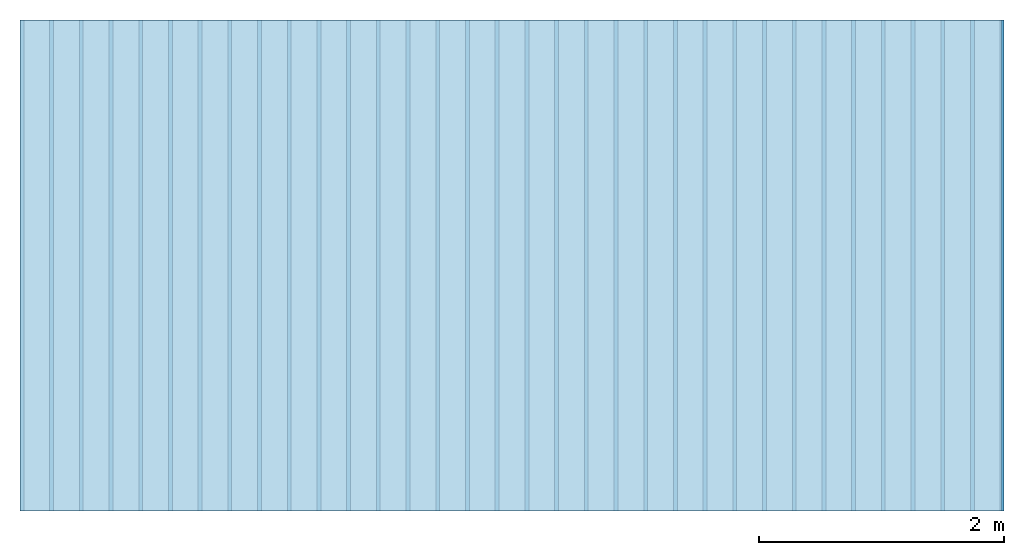
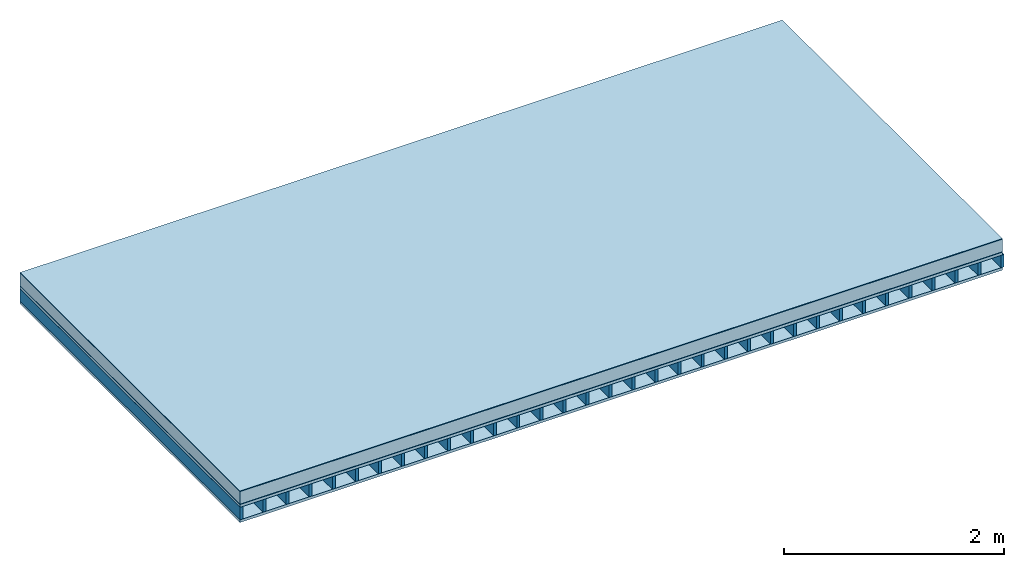
# One storey: 6 plates, 1 member, 1 element without a shape of its own.
"""IFC4 building model written with IfcOpenShell, lengths in metres."""

import ifcopenshell
import ifcopenshell.guid

model = None  # the IFC model being written
_history = None  # IfcOwnerHistory: only IFC2X3 demands one
_inside = {}  # id of a spatial element -> (the spatial element, [elements in it])
_under = {}  # id of a project, library or spatial element -> (it, [spatial elements below it])
_declared = {}  # id of a project -> (the project, [libraries it declares])
_typed = {}  # id of a type object -> (the type object, [elements of that type])
_made_of = {}  # id of a material, layer set ... -> (it, [elements and type objects made of it])


def new_model(schema):
    """Start an empty IFC model of exactly this schema.

    Asked for "IFC4X3", IfcOpenShell would pick the latest addendum, in which some entities
    have other attributes; the version numbers below select the first issue.
    IFC2X3 requires an IfcOwnerHistory on every rooted entity: one is made here for all.
    """
    global model, _history
    if schema == "IFC4X3":
        model = ifcopenshell.file(schema_version=(4, 3, 0, 0))
    else:
        model = ifcopenshell.file(schema=schema)
    _inside.clear()
    _under.clear()
    _declared.clear()
    _typed.clear()
    _made_of.clear()
    _history = None
    if model.schema == "IFC2X3":
        org = make("IfcOrganization", Name="unknown")
        user = make(
            "IfcPersonAndOrganization",
            ThePerson=make("IfcPerson", FamilyName="unknown"),
            TheOrganization=org,
        )
        app = make(
            "IfcApplication",
            ApplicationDeveloper=org,
            Version="unknown",
            ApplicationFullName="unknown",
            ApplicationIdentifier="unknown",
        )
        _history = make(
            "IfcOwnerHistory",
            OwningUser=user,
            OwningApplication=app,
            ChangeAction="ADDED",
            CreationDate=0,
        )
    return model


def make(cls, **values):
    """One entity of the class cls with the attributes given. An attribute that is None is left unset."""
    return model.create_entity(
        cls, **{name: value for name, value in values.items() if value is not None}
    )


def rooted(cls, **values):
    """An entity with a GlobalId (a new one), such as an element, a storey or a relation."""
    return make(cls, GlobalId=ifcopenshell.guid.new(), OwnerHistory=_history, **values)


def si_unit(unit_type, name, prefix=None):
    """IfcSIUnit, for example si_unit("LENGTHUNIT", "METRE", prefix="MILLI")."""
    return make("IfcSIUnit", UnitType=unit_type, Prefix=prefix, Name=name)


def derived_unit(unit_type, elements):
    """IfcDerivedUnit: a product of units, each with its exponent."""
    return make(
        "IfcDerivedUnit",
        Elements=[
            make("IfcDerivedUnitElement", Unit=unit, Exponent=power)
            for unit, power in elements
        ],
        UnitType=unit_type,
    )


def assignment(units):
    """IfcUnitAssignment: the units of a project."""
    return None if units is None else make("IfcUnitAssignment", Units=units)


def point(xyz):
    """IfcCartesianPoint."""
    return None if xyz is None else make("IfcCartesianPoint", Coordinates=xyz)


def direction(xyz):
    """IfcDirection."""
    return None if xyz is None else make("IfcDirection", DirectionRatios=xyz)


def frame(location, z_axis=None, x_axis=None):
    """IfcAxis2Placement3D, a coordinate frame: its origin and axes. An axis left out is left unset."""
    return make(
        "IfcAxis2Placement3D",
        Location=point(location),
        Axis=direction(z_axis),
        RefDirection=direction(x_axis),
    )


def frame_2d(location, x_axis=None):
    """IfcAxis2Placement2D, a coordinate frame in the plane: its origin and x axis."""
    return make(
        "IfcAxis2Placement2D", Location=point(location), RefDirection=direction(x_axis)
    )


def origin():
    """The frame at (0, 0, 0) with its axes left unset."""
    return frame((0.0, 0.0, 0.0))


def origin_with_axes():
    """The frame at (0, 0, 0) with the z axis (0, 0, 1) and the x axis (1, 0, 0) written out."""
    return frame((0.0, 0.0, 0.0), z_axis=(0.0, 0.0, 1.0), x_axis=(1.0, 0.0, 0.0))


def place(relative_to, where):
    """IfcLocalPlacement: puts the frame where relative to a parent placement (None: the world)."""
    return make(
        "IfcLocalPlacement", PlacementRelTo=relative_to, RelativePlacement=where
    )


def context(
    kind, dimensions, precision=None, world=None, true_north=None, identifier=None
):
    """IfcGeometricRepresentationContext, for example the 3D "Model" context."""
    return make(
        "IfcGeometricRepresentationContext",
        ContextIdentifier=identifier,
        ContextType=kind,
        CoordinateSpaceDimension=dimensions,
        Precision=precision,
        WorldCoordinateSystem=world,
        TrueNorth=true_north,
    )


def project(units=None, contexts=None):
    """IfcProject with its units and contexts."""
    return rooted(
        "IfcProject",
        Name="project",
        RepresentationContexts=contexts,
        UnitsInContext=assignment(units),
    )


def spatial(cls, under=None, at=None, **own):
    """A site, building, storey or space (cls), placed at a placement, below another one or the project."""
    s = rooted(cls, ObjectPlacement=at, **own)
    if under is not None:
        _under.setdefault(under.id(), (under, []))[1].append(s)
    return s


def profile(cls, at=None, kind="AREA", **sizes):
    """A parametric profile (cls). Its sizes go by their IFC names, for example OverallWidth=200.0."""
    return make(cls, ProfileType=kind, Position=at, **sizes)


def rectangle(**sizes):
    """IfcRectangleProfileDef."""
    return profile("IfcRectangleProfileDef", **sizes)


def extrude(swept, where, along, depth):
    """IfcExtrudedAreaSolid: the profile swept, set in the frame where, extruded along a direction by depth."""
    return make(
        "IfcExtrudedAreaSolid",
        SweptArea=swept,
        Position=where,
        ExtrudedDirection=direction(along),
        Depth=depth,
    )


def shape(context_of_items, identifier, shape_type, items):
    """IfcShapeRepresentation: the items that make up one representation, for example the "Body"."""
    return make(
        "IfcShapeRepresentation",
        ContextOfItems=context_of_items,
        RepresentationIdentifier=identifier,
        RepresentationType=shape_type,
        Items=items,
    )


def material(Name=None, Category=None):
    """IfcMaterial."""
    return make("IfcMaterial", Name=Name, Category=Category)


def layer(
    of_material, thickness, ventilated=None, Name=None, Category=None, Priority=None
):
    """IfcMaterialLayer: one layer of a wall or slab, of a material (None: an air gap)."""
    return make(
        "IfcMaterialLayer",
        Material=of_material,
        LayerThickness=thickness,
        IsVentilated=ventilated,
        Name=Name,
        Category=Category,
        Priority=Priority,
    )


def layer_set(layers, Name=None):
    """IfcMaterialLayerSet."""
    return make("IfcMaterialLayerSet", MaterialLayers=layers, LayerSetName=Name)


def made_of(thing, what):
    """Note that an element or type object is made of a material, layer set ...; save() writes the relation."""
    if what is not None:
        _made_of.setdefault(what.id(), (what, []))[1].append(thing)
    return thing


def type_object(cls, material=None, **own):
    """A type object (cls), such as IfcWallType, which elements share."""
    return made_of(rooted(cls, **own), material)


def element(
    cls,
    number,
    at=None,
    inside=None,
    cuts=None,
    type_object=None,
    material=None,
    context=None,
    identifier="Body",
    shape_type=None,
    held_by="IfcProductDefinitionShape",
    body=None,
    shapes=None,
    **own,
):
    """One element of the class cls, such as IfcWall. Its Tag is "e" and its number.

    at: its placement. inside: the storey or other place that contains it. cuts: it is an
    opening in that element (IfcRelVoidsElement). A single representation is given by context,
    identifier, shape_type and body (its items); several are given by shapes. held_by: the class
    of the entity that holds the representations. save() writes the other relations.
    """
    e = rooted(cls, Tag="e%d" % number, ObjectPlacement=at, **own)
    if body is not None:
        shapes = [shape(context, identifier, shape_type, body)]
    if shapes is not None:
        e.Representation = make(held_by, Representations=shapes)
    if inside is not None:
        _inside.setdefault(inside.id(), (inside, []))[1].append(e)
    if cuts is not None:
        rooted(
            "IfcRelVoidsElement", RelatingBuildingElement=cuts, RelatedOpeningElement=e
        )
    if type_object is not None:
        _typed.setdefault(type_object.id(), (type_object, []))[1].append(e)
    return made_of(e, material)


def aggregate(whole, parts):
    """IfcRelAggregates: a whole, such as a stair, and the parts it consists of."""
    return rooted("IfcRelAggregates", RelatingObject=whole, RelatedObjects=parts)


def save(model, path):
    """Write the relations noted so far, then the file.

    IfcRelAggregates (storeys below a building ...), IfcRelContainedInSpatialStructure (elements
    in a storey), IfcRelDefinesByType, IfcRelAssociatesMaterial and IfcRelDeclares: one each for
    every whole, place, type object, material and project.
    """
    for whole, parts in _under.values():
        aggregate(whole, parts)
    for where, things in _inside.values():
        rooted(
            "IfcRelContainedInSpatialStructure",
            RelatedElements=things,
            RelatingStructure=where,
        )
    for kind, things in _typed.values():
        rooted("IfcRelDefinesByType", RelatedObjects=things, RelatingType=kind)
    for what, things in _made_of.values():
        rooted("IfcRelAssociatesMaterial", RelatedObjects=things, RelatingMaterial=what)
    for by, libraries in _declared.values():
        rooted("IfcRelDeclares", RelatingContext=by, RelatedDefinitions=libraries)
    model.write(path)


model = new_model("IFC4")

# Units and contexts
plan_context = context("Plan", 3, precision=1e-05, world=origin(), true_north=direction((0.0, 1.0)))
model_context = context("Model", 3, precision=1e-05, world=origin(), true_north=direction((0.0, 1.0)))
ifc_project = project(units=[si_unit("LENGTHUNIT", "METRE"), derived_unit("SOUNDPRESSUREUNIT", [(si_unit("PRESSUREUNIT", "PASCAL", prefix="MICRO"), 0)]), si_unit("ENERGYUNIT", "JOULE", prefix="MEGA"), si_unit("MASSUNIT", "GRAM", prefix="KILO"), derived_unit("THERMALTRANSMITTANCEUNIT", [(si_unit("POWERUNIT", "WATT"), 1), (si_unit("AREAUNIT", "SQUARE_METRE"), -1), (si_unit("THERMODYNAMICTEMPERATUREUNIT", "KELVIN"), -1)]), derived_unit("AREADENSITYUNIT", [(si_unit("MASSUNIT", "GRAM", prefix="KILO"), 1), (si_unit("AREAUNIT", "SQUARE_METRE"), -1)]), derived_unit("USERDEFINED", [(si_unit("ENERGYUNIT", "JOULE", prefix="MEGA"), 1), (si_unit("AREAUNIT", "SQUARE_METRE"), -1)])], contexts=[plan_context, model_context])

# Site, building, storey
site = spatial("IfcSite", under=ifc_project)
building_placement = place(None, origin())
building = spatial("IfcBuilding", under=site, at=building_placement)
storey_placement = place(building_placement, origin())
storey = spatial("IfcBuildingStorey", under=building, at=storey_placement)

# Slab, member, plates
ifc_material_1 = material(Name="Protective layer", Category="09.007")
ifc_layer_1 = layer(ifc_material_1, 0.001, Name="Use and protection layer 1")
ifc_material_2 = material(Name="Roofing underlay", Category="09.008")
ifc_layer_2 = layer(ifc_material_2, 0.005, Name="Under the roof")
ifc_material_3 = material(Name="Bauder PIR", Category="10.006")
ifc_layer_3 = layer(ifc_material_3, 0.14, Name="Exterior insulation layer 1")
ifc_material_4 = material(Name="BauderTHERM DS 1 DUO", Category="09.001")
ifc_layer_4 = layer(ifc_material_4, 0.004, Name="layer / temporary roof")
ifc_material_5 = material(Name="surface element sheathing above")
ifc_layer_5 = layer(ifc_material_5, 0.031, Name="above 1st layer")
ifc_layer_6 = layer(None, 0.138, Name="Support")
ifc_material_6 = material(Name="surface element sheathing below")
ifc_layer_7 = layer(ifc_material_6, 0.031, Name="Lower layer 1")
ifc_layer_set = layer_set([ifc_layer_1, ifc_layer_2, ifc_layer_3, ifc_layer_4, ifc_layer_5, ifc_layer_6, ifc_layer_7])
slab_type = type_object("IfcSlabType", Name="F0124", PredefinedType="NOTDEFINED", material=ifc_layer_set)
slab_placement = place(None, frame((0.0, 0.0, 0.0), z_axis=(0.0, 0.0, -1.0), x_axis=(1.0, 0.0, 0.0)))
slab = element("IfcSlab", 1, at=slab_placement, inside=storey, type_object=slab_type, material=ifc_layer_set, Name="Slab #1")
ifc_material_7 = material(Name="surface element LFE")
member_placement = place(slab_placement, origin())
member = element("IfcMember", 2, at=member_placement, material=ifc_material_7, Name="Support", context=plan_context, shape_type="SweptSolid", body=[
    extrude(rectangle(XDim=0.031, YDim=0.138, at=frame_2d((0.0155, 0.069), x_axis=(1.0, 0.0))), frame((0.0, 4.0, 0.181), z_axis=(0.0, -1.0, 0.0), x_axis=(1.0, 0.0, 0.0)), (0.0, 0.0, 1.0), 4.0),
    extrude(rectangle(XDim=0.031, YDim=0.138, at=frame_2d((0.0155, 0.069), x_axis=(1.0, 0.0))), frame((0.242, 4.0, 0.181), z_axis=(0.0, -1.0, 0.0), x_axis=(1.0, 0.0, 0.0)), (0.0, 0.0, 1.0), 4.0),
    extrude(rectangle(XDim=0.031, YDim=0.138, at=frame_2d((0.0155, 0.069), x_axis=(1.0, 0.0))), frame((0.484, 4.0, 0.181), z_axis=(0.0, -1.0, 0.0), x_axis=(1.0, 0.0, 0.0)), (0.0, 0.0, 1.0), 4.0),
    extrude(rectangle(XDim=0.031, YDim=0.138, at=frame_2d((0.0155, 0.069), x_axis=(1.0, 0.0))), frame((0.726, 4.0, 0.181), z_axis=(0.0, -1.0, 0.0), x_axis=(1.0, 0.0, 0.0)), (0.0, 0.0, 1.0), 4.0),
    extrude(rectangle(XDim=0.031, YDim=0.138, at=frame_2d((0.0155, 0.069), x_axis=(1.0, 0.0))), frame((0.968, 4.0, 0.181), z_axis=(0.0, -1.0, 0.0), x_axis=(1.0, 0.0, 0.0)), (0.0, 0.0, 1.0), 4.0),
    extrude(rectangle(XDim=0.031, YDim=0.138, at=frame_2d((0.0155, 0.069), x_axis=(1.0, 0.0))), frame((1.21, 4.0, 0.181), z_axis=(0.0, -1.0, 0.0), x_axis=(1.0, 0.0, 0.0)), (0.0, 0.0, 1.0), 4.0),
    extrude(rectangle(XDim=0.031, YDim=0.138, at=frame_2d((0.0155, 0.069), x_axis=(1.0, 0.0))), frame((1.452, 4.0, 0.181), z_axis=(0.0, -1.0, 0.0), x_axis=(1.0, 0.0, 0.0)), (0.0, 0.0, 1.0), 4.0),
    extrude(rectangle(XDim=0.031, YDim=0.138, at=frame_2d((0.0155, 0.069), x_axis=(1.0, 0.0))), frame((1.694, 4.0, 0.181), z_axis=(0.0, -1.0, 0.0), x_axis=(1.0, 0.0, 0.0)), (0.0, 0.0, 1.0), 4.0),
    extrude(rectangle(XDim=0.031, YDim=0.138, at=frame_2d((0.0155, 0.069), x_axis=(1.0, 0.0))), frame((1.936, 4.0, 0.181), z_axis=(0.0, -1.0, 0.0), x_axis=(1.0, 0.0, 0.0)), (0.0, 0.0, 1.0), 4.0),
    extrude(rectangle(XDim=0.031, YDim=0.138, at=frame_2d((0.0155, 0.069), x_axis=(1.0, 0.0))), frame((2.178, 4.0, 0.181), z_axis=(0.0, -1.0, 0.0), x_axis=(1.0, 0.0, 0.0)), (0.0, 0.0, 1.0), 4.0),
    extrude(rectangle(XDim=0.031, YDim=0.138, at=frame_2d((0.0155, 0.069), x_axis=(1.0, 0.0))), frame((2.42, 4.0, 0.181), z_axis=(0.0, -1.0, 0.0), x_axis=(1.0, 0.0, 0.0)), (0.0, 0.0, 1.0), 4.0),
    extrude(rectangle(XDim=0.031, YDim=0.138, at=frame_2d((0.0155, 0.069), x_axis=(1.0, 0.0))), frame((2.662, 4.0, 0.181), z_axis=(0.0, -1.0, 0.0), x_axis=(1.0, 0.0, 0.0)), (0.0, 0.0, 1.0), 4.0),
    extrude(rectangle(XDim=0.031, YDim=0.138, at=frame_2d((0.0155, 0.069), x_axis=(1.0, 0.0))), frame((2.904, 4.0, 0.181), z_axis=(0.0, -1.0, 0.0), x_axis=(1.0, 0.0, 0.0)), (0.0, 0.0, 1.0), 4.0),
    extrude(rectangle(XDim=0.031, YDim=0.138, at=frame_2d((0.0155, 0.069), x_axis=(1.0, 0.0))), frame((3.146, 4.0, 0.181), z_axis=(0.0, -1.0, 0.0), x_axis=(1.0, 0.0, 0.0)), (0.0, 0.0, 1.0), 4.0),
    extrude(rectangle(XDim=0.031, YDim=0.138, at=frame_2d((0.0155, 0.069), x_axis=(1.0, 0.0))), frame((3.388, 4.0, 0.181), z_axis=(0.0, -1.0, 0.0), x_axis=(1.0, 0.0, 0.0)), (0.0, 0.0, 1.0), 4.0),
    extrude(rectangle(XDim=0.031, YDim=0.138, at=frame_2d((0.0155, 0.069), x_axis=(1.0, 0.0))), frame((3.63, 4.0, 0.181), z_axis=(0.0, -1.0, 0.0), x_axis=(1.0, 0.0, 0.0)), (0.0, 0.0, 1.0), 4.0),
    extrude(rectangle(XDim=0.031, YDim=0.138, at=frame_2d((0.0155, 0.069), x_axis=(1.0, 0.0))), frame((3.872, 4.0, 0.181), z_axis=(0.0, -1.0, 0.0), x_axis=(1.0, 0.0, 0.0)), (0.0, 0.0, 1.0), 4.0),
    extrude(rectangle(XDim=0.031, YDim=0.138, at=frame_2d((0.0155, 0.069), x_axis=(1.0, 0.0))), frame((4.114, 4.0, 0.181), z_axis=(0.0, -1.0, 0.0), x_axis=(1.0, 0.0, 0.0)), (0.0, 0.0, 1.0), 4.0),
    extrude(rectangle(XDim=0.031, YDim=0.138, at=frame_2d((0.0155, 0.069), x_axis=(1.0, 0.0))), frame((4.356, 4.0, 0.181), z_axis=(0.0, -1.0, 0.0), x_axis=(1.0, 0.0, 0.0)), (0.0, 0.0, 1.0), 4.0),
    extrude(rectangle(XDim=0.031, YDim=0.138, at=frame_2d((0.0155, 0.069), x_axis=(1.0, 0.0))), frame((4.598, 4.0, 0.181), z_axis=(0.0, -1.0, 0.0), x_axis=(1.0, 0.0, 0.0)), (0.0, 0.0, 1.0), 4.0),
    extrude(rectangle(XDim=0.031, YDim=0.138, at=frame_2d((0.0155, 0.069), x_axis=(1.0, 0.0))), frame((4.84, 4.0, 0.181), z_axis=(0.0, -1.0, 0.0), x_axis=(1.0, 0.0, 0.0)), (0.0, 0.0, 1.0), 4.0),
    extrude(rectangle(XDim=0.031, YDim=0.138, at=frame_2d((0.0155, 0.069), x_axis=(1.0, 0.0))), frame((5.082, 4.0, 0.181), z_axis=(0.0, -1.0, 0.0), x_axis=(1.0, 0.0, 0.0)), (0.0, 0.0, 1.0), 4.0),
    extrude(rectangle(XDim=0.031, YDim=0.138, at=frame_2d((0.0155, 0.069), x_axis=(1.0, 0.0))), frame((5.324, 4.0, 0.181), z_axis=(0.0, -1.0, 0.0), x_axis=(1.0, 0.0, 0.0)), (0.0, 0.0, 1.0), 4.0),
    extrude(rectangle(XDim=0.031, YDim=0.138, at=frame_2d((0.0155, 0.069), x_axis=(1.0, 0.0))), frame((5.566, 4.0, 0.181), z_axis=(0.0, -1.0, 0.0), x_axis=(1.0, 0.0, 0.0)), (0.0, 0.0, 1.0), 4.0),
    extrude(rectangle(XDim=0.031, YDim=0.138, at=frame_2d((0.0155, 0.069), x_axis=(1.0, 0.0))), frame((5.808, 4.0, 0.181), z_axis=(0.0, -1.0, 0.0), x_axis=(1.0, 0.0, 0.0)), (0.0, 0.0, 1.0), 4.0),
    extrude(rectangle(XDim=0.031, YDim=0.138, at=frame_2d((0.0155, 0.069), x_axis=(1.0, 0.0))), frame((6.05, 4.0, 0.181), z_axis=(0.0, -1.0, 0.0), x_axis=(1.0, 0.0, 0.0)), (0.0, 0.0, 1.0), 4.0),
    extrude(rectangle(XDim=0.031, YDim=0.138, at=frame_2d((0.0155, 0.069), x_axis=(1.0, 0.0))), frame((6.292, 4.0, 0.181), z_axis=(0.0, -1.0, 0.0), x_axis=(1.0, 0.0, 0.0)), (0.0, 0.0, 1.0), 4.0),
    extrude(rectangle(XDim=0.031, YDim=0.138, at=frame_2d((0.0155, 0.069), x_axis=(1.0, 0.0))), frame((6.534, 4.0, 0.181), z_axis=(0.0, -1.0, 0.0), x_axis=(1.0, 0.0, 0.0)), (0.0, 0.0, 1.0), 4.0),
    extrude(rectangle(XDim=0.031, YDim=0.138, at=frame_2d((0.0155, 0.069), x_axis=(1.0, 0.0))), frame((6.776, 4.0, 0.181), z_axis=(0.0, -1.0, 0.0), x_axis=(1.0, 0.0, 0.0)), (0.0, 0.0, 1.0), 4.0),
    extrude(rectangle(XDim=0.031, YDim=0.138, at=frame_2d((0.0155, 0.069), x_axis=(1.0, 0.0))), frame((7.018, 4.0, 0.181), z_axis=(0.0, -1.0, 0.0), x_axis=(1.0, 0.0, 0.0)), (0.0, 0.0, 1.0), 4.0),
    extrude(rectangle(XDim=0.031, YDim=0.138, at=frame_2d((0.0155, 0.069), x_axis=(1.0, 0.0))), frame((7.26, 4.0, 0.181), z_axis=(0.0, -1.0, 0.0), x_axis=(1.0, 0.0, 0.0)), (0.0, 0.0, 1.0), 4.0),
    extrude(rectangle(XDim=0.031, YDim=0.138, at=frame_2d((0.0155, 0.069), x_axis=(1.0, 0.0))), frame((7.502, 4.0, 0.181), z_axis=(0.0, -1.0, 0.0), x_axis=(1.0, 0.0, 0.0)), (0.0, 0.0, 1.0), 4.0),
    extrude(rectangle(XDim=0.031, YDim=0.138, at=frame_2d((0.0155, 0.069), x_axis=(1.0, 0.0))), frame((7.744, 4.0, 0.181), z_axis=(0.0, -1.0, 0.0), x_axis=(1.0, 0.0, 0.0)), (0.0, 0.0, 1.0), 4.0),
    extrude(rectangle(XDim=0.031, YDim=0.138, at=frame_2d((0.0155, 0.069), x_axis=(1.0, 0.0))), frame((7.986, 4.0, 0.181), z_axis=(0.0, -1.0, 0.0), x_axis=(1.0, 0.0, 0.0)), (0.0, 0.0, 1.0), 4.0),
])
plate_1_placement = place(slab_placement, origin())
plate_1 = element("IfcPlate", 3, at=plate_1_placement, material=ifc_material_1, Name="Use and protection layer 1", context=plan_context, shape_type="SweptSolid", body=[
    extrude(rectangle(XDim=8.0, YDim=4.0, at=frame_2d((4.0, 2.0), x_axis=(1.0, 0.0))), origin_with_axes(), (0.0, 0.0, 1.0), 0.001),
])
plate_2_placement = place(slab_placement, origin())
plate_2 = element("IfcPlate", 4, at=plate_2_placement, material=ifc_material_2, Name="Under the roof", context=plan_context, shape_type="SweptSolid", body=[
    extrude(rectangle(XDim=8.0, YDim=4.0, at=frame_2d((4.0, 2.0), x_axis=(1.0, 0.0))), frame((0.0, 0.0, 0.001), z_axis=(0.0, 0.0, 1.0), x_axis=(1.0, 0.0, 0.0)), (0.0, 0.0, 1.0), 0.005),
])
plate_3_placement = place(slab_placement, origin())
plate_3 = element("IfcPlate", 5, at=plate_3_placement, material=ifc_material_3, Name="Exterior insulation layer 1", context=plan_context, shape_type="SweptSolid", body=[
    extrude(rectangle(XDim=8.0, YDim=4.0, at=frame_2d((4.0, 2.0), x_axis=(1.0, 0.0))), frame((0.0, 0.0, 0.006), z_axis=(0.0, 0.0, 1.0), x_axis=(1.0, 0.0, 0.0)), (0.0, 0.0, 1.0), 0.14),
])
plate_4_placement = place(slab_placement, origin())
plate_4 = element("IfcPlate", 6, at=plate_4_placement, material=ifc_material_4, Name="layer / temporary roof", context=plan_context, shape_type="SweptSolid", body=[
    extrude(rectangle(XDim=8.0, YDim=4.0, at=frame_2d((4.0, 2.0), x_axis=(1.0, 0.0))), frame((0.0, 0.0, 0.146), z_axis=(0.0, 0.0, 1.0), x_axis=(1.0, 0.0, 0.0)), (0.0, 0.0, 1.0), 0.004),
])
plate_5_placement = place(slab_placement, origin())
plate_5 = element("IfcPlate", 7, at=plate_5_placement, material=ifc_material_5, Name="above 1st layer", context=plan_context, shape_type="SweptSolid", body=[
    extrude(rectangle(XDim=8.0, YDim=4.0, at=frame_2d((4.0, 2.0), x_axis=(1.0, 0.0))), frame((0.0, 0.0, 0.15), z_axis=(0.0, 0.0, 1.0), x_axis=(1.0, 0.0, 0.0)), (0.0, 0.0, 1.0), 0.031),
])
plate_6_placement = place(slab_placement, origin())
plate_6 = element("IfcPlate", 8, at=plate_6_placement, material=ifc_material_6, Name="Lower layer 1", context=plan_context, shape_type="SweptSolid", body=[
    extrude(rectangle(XDim=8.0, YDim=4.0, at=frame_2d((4.0, 2.0), x_axis=(1.0, 0.0))), frame((0.0, 0.0, 0.319), z_axis=(0.0, 0.0, 1.0), x_axis=(1.0, 0.0, 0.0)), (0.0, 0.0, 1.0), 0.031),
])
aggregate(slab, [plate_1, plate_2, plate_3, plate_4, plate_5, member, plate_6])

save(model, "model.ifc")
